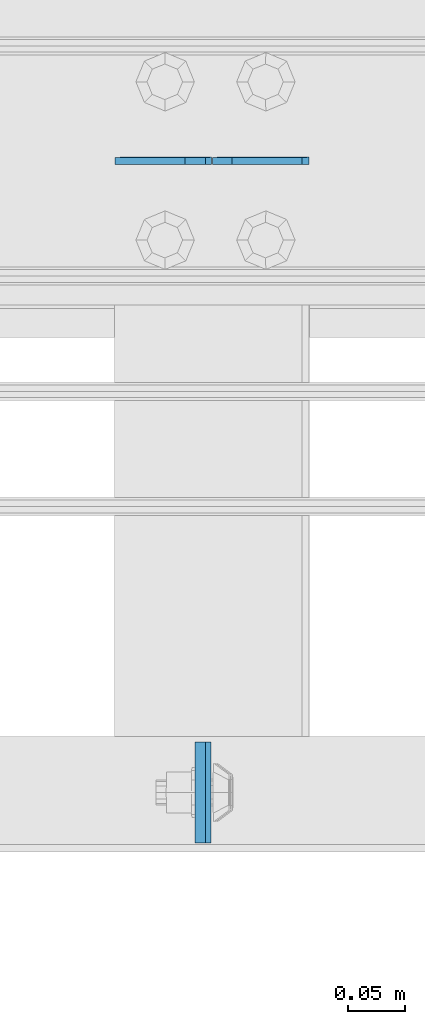
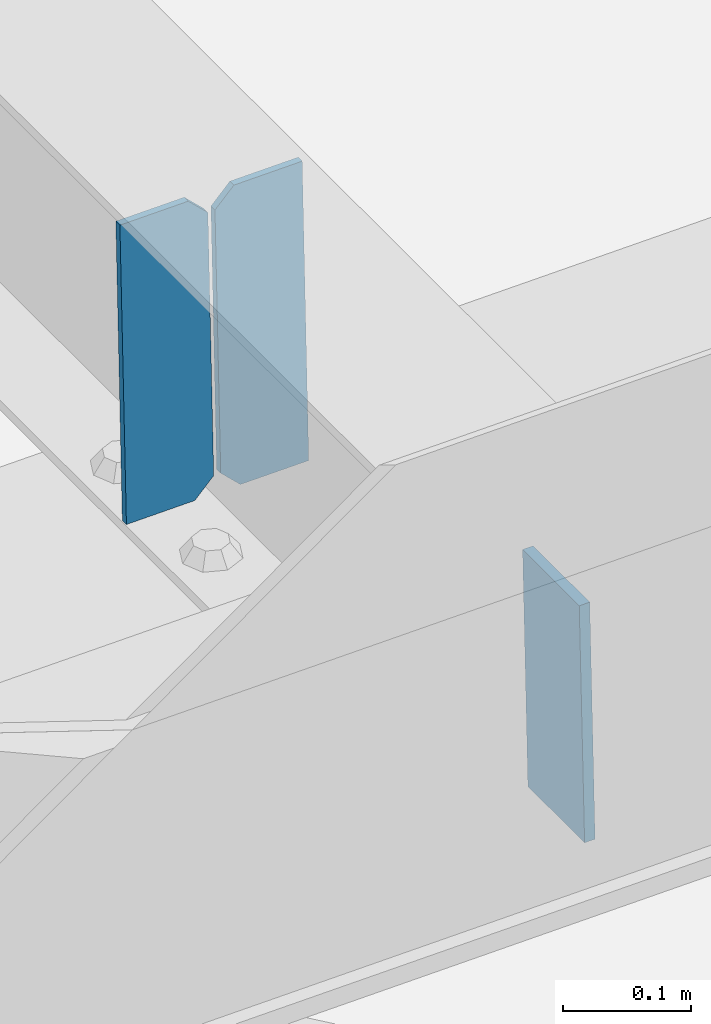
# One storey, part 3155 of 3843: 3 plates, 2 elements without a shape of their own.
"""IFC2X3 building model written with IfcOpenShell, lengths in millimetres."""

from ifc_helpers import new_model, si_unit, frame, origin_with_axes, place, context, subcontext, project, spatial, faceted_brep, material, type_object, element, aggregate, save


model = new_model("IFC2X3")

# Units and contexts
model_context = context("Model", 3, precision=1e-05, world=origin_with_axes())
body_context = subcontext(model_context, "Body", "Model", "MODEL_VIEW")
ifc_project = project(units=[si_unit("LENGTHUNIT", "METRE", prefix="MILLI"), si_unit("AREAUNIT", "SQUARE_METRE"), si_unit("VOLUMEUNIT", "CUBIC_METRE"), si_unit("MASSUNIT", "GRAM", prefix="KILO"), si_unit("TIMEUNIT", "SECOND"), si_unit("PLANEANGLEUNIT", "RADIAN"), si_unit("SOLIDANGLEUNIT", "STERADIAN"), si_unit("THERMODYNAMICTEMPERATUREUNIT", "DEGREE_CELSIUS"), si_unit("LUMINOUSINTENSITYUNIT", "LUMEN")], contexts=[model_context])

# Site, building, storey
site_placement = place(None, origin_with_axes())
site = spatial("IfcSite", under=ifc_project, at=site_placement, CompositionType="ELEMENT")
building_placement = place(site_placement, origin_with_axes())
building = spatial("IfcBuilding", under=site, at=building_placement, Name="Undefined", CompositionType="ELEMENT")
storey_placement = place(building_placement, origin_with_axes())
storey = spatial("IfcBuildingStorey", under=building, at=storey_placement, Name="Undefined", CompositionType="ELEMENT", Elevation=0.0)

# Assembly, plate
assembly_1_placement = place(storey_placement, origin_with_axes())
assembly_1 = element("IfcElementAssembly", 1, at=assembly_1_placement, inside=storey, Name="BEAM", AssemblyPlace="NOTDEFINED", PredefinedType="RIGID_FRAME")
ifc_material = material(Name="STEEL/A572-50")
plate_type_1 = type_object("IfcPlateType", PredefinedType="NOTDEFINED")
plate_1_placement = place(assembly_1_placement, frame((57593.4876168516, 25014.2376157136, 46136.2098430792), z_axis=(2.42770079421462e-05, 0.999999999705182, 5.13624225277454e-07), x_axis=(0.0211520550054438, 0.0, -0.999776270257025)))
plate_1 = element("IfcPlate", 2, at=plate_1_placement, type_object=plate_type_1, material=ifc_material, Name="PLATE", context=body_context, shape_type="Brep", body=[
    faceted_brep([(0.0, -4.76249999999709, 0.0), (0.0, -4.76249999999709, 88.9000015258789), (0.0, 4.76249999999709, 88.9000015258789), (0.0, 4.76249999999709, 0.0), (228.600006102781, -4.7625000004191, 88.9000015257589), (228.600006102781, 4.76249999954598, 88.9000015257443), (228.600006103079, -4.7625000004482, 7.27595761418343e-12), (228.600006103079, 4.76249999954598, -7.27595761418343e-12)], [[[0, 1, 2, 3]], [[1, 4, 5, 2]], [[4, 6, 7, 5]], [[6, 0, 3, 7]], [[5, 7, 3, 2]], [[6, 4, 1, 0]]]),
])
aggregate(assembly_1, [plate_1])

# Assembly, plates
assembly_2_placement = place(storey_placement, origin_with_axes())
assembly_2 = element("IfcElementAssembly", 3, at=assembly_2_placement, inside=storey, Name="BEAM", AssemblyPlace="NOTDEFINED", PredefinedType="RIGID_FRAME")
plate_type_2 = type_object("IfcPlateType", PredefinedType="NOTDEFINED")
plate_2_placement = place(assembly_2_placement, frame((57689.4964782646, 25616.0894118734, 45876.8847078248), z_axis=(-0.0211520979449343, -0.00114771899950938, 0.999775610571505), x_axis=(-0.999776269348562, 2.42819999967805e-05, -0.0211520840074087)))
plate_2 = element("IfcPlate", 4, at=plate_2_placement, type_object=plate_type_2, material=ifc_material, Name="STIFFENER", context=body_context, shape_type="Brep", body=[
    faceted_brep([(0.0, -3.17499999999927, 0.0), (6.83940015733242e-10, -3.17499999996653, 288.924999998613), (6.54836185276508e-10, 3.17500000001746, 288.924999998591), (0.0, 3.17499999999927, 0.0), (61.9125003828667, -3.17499999997744, 288.924999998599), (61.9125003828522, 3.17500000002838, 288.924999998584), (79.3750000013097, -3.17499999997744, 271.462500380039), (79.375000001266, 3.17500000002838, 271.462500380017), (79.375000000713, -3.17499999999927, 17.4624996185448), (79.3750000006694, 3.17500000000291, 17.462499618523), (61.9125003821828, -3.17499999999563, -1.45519152283669e-11), (61.9125003821682, 3.17500000000655, -2.91038304567337e-11)], [[[0, 1, 2, 3]], [[1, 4, 5, 2]], [[4, 6, 7, 5]], [[6, 8, 9, 7]], [[8, 10, 11, 9]], [[10, 0, 3, 11]], [[5, 7, 9, 11, 3, 2]], [[10, 8, 6, 4, 1, 0]]]),
])
plate_3_placement = place(assembly_2_placement, frame((57603.7906575749, 25616.0914934562, 45875.0714454196), z_axis=(-0.0211520979449343, -0.00114771899950938, 0.999775610571505), x_axis=(-0.999776269348562, 2.42819999967805e-05, -0.0211520840074087)))
plate_3 = element("IfcPlate", 5, at=plate_3_placement, type_object=plate_type_2, material=ifc_material, Name="STIFFENER", context=body_context, shape_type="Brep", body=[
    faceted_brep([(5.82076609134674e-11, -3.17499999999927, 17.4624996185667), (6.25732354819775e-10, -3.17499999997744, 271.462500380054), (5.82076609134674e-10, 3.17500000002474, 271.462500380039), (0.0, 3.17500000000655, 17.4624996185521), (17.462499619156, -3.17499999997744, 288.924999998606), (17.4624996191269, 3.17500000002474, 288.924999998591), (79.3750000013242, -3.17500000025029, 288.924999998591), (79.3750000013097, 3.1749999997337, 288.92499999857), (79.3750000006548, -3.17500000026484, -2.18278728425503e-11), (79.3750000006403, 3.17499999969732, -2.91038304567337e-11), (17.4624996184866, -3.17500000000291, 7.27595761418343e-12), (17.462499618443, 3.17500000000291, -7.27595761418343e-12)], [[[0, 1, 2, 3]], [[1, 4, 5, 2]], [[4, 6, 7, 5]], [[6, 8, 9, 7]], [[8, 10, 11, 9]], [[10, 0, 3, 11]], [[5, 7, 9, 11, 3, 2]], [[10, 8, 6, 4, 1, 0]]]),
])
aggregate(assembly_2, [plate_2, plate_3])

save(model, "model.ifc")
